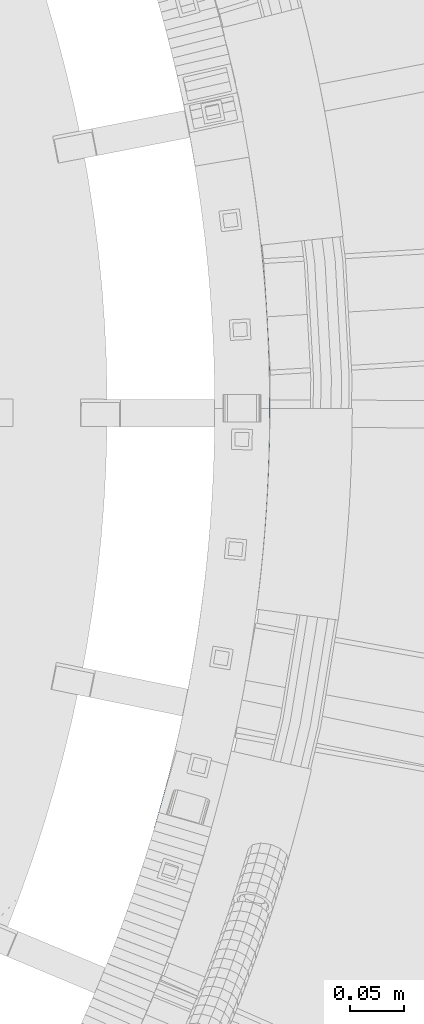
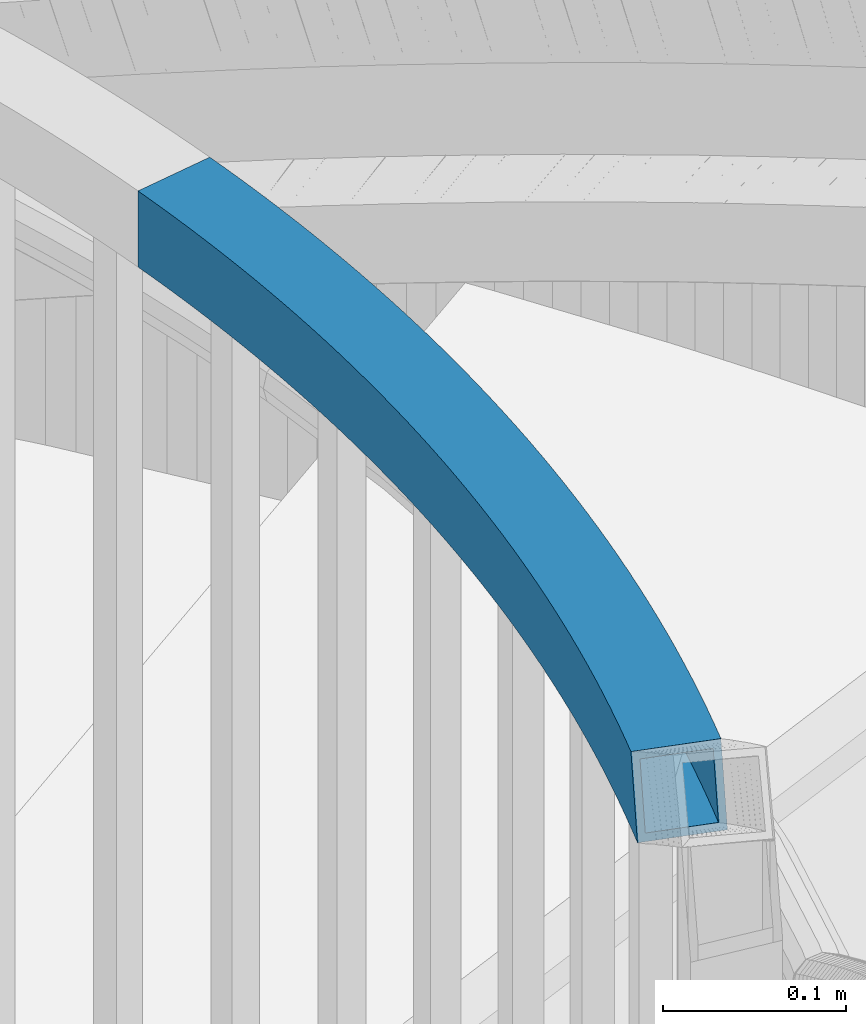
# One storey, part 499 of 975: 1 beam.
"""IFC2X3 building model written with IfcOpenShell, lengths in millimetres."""

import ifcopenshell
import ifcopenshell.guid

model = None  # the IFC model being written
_history = None  # IfcOwnerHistory: only IFC2X3 demands one
_inside = {}  # id of a spatial element -> (the spatial element, [elements in it])
_under = {}  # id of a project, library or spatial element -> (it, [spatial elements below it])
_declared = {}  # id of a project -> (the project, [libraries it declares])
_typed = {}  # id of a type object -> (the type object, [elements of that type])
_made_of = {}  # id of a material, layer set ... -> (it, [elements and type objects made of it])


def new_model(schema):
    """Start an empty IFC model of exactly this schema.

    Asked for "IFC4X3", IfcOpenShell would pick the latest addendum, in which some entities
    have other attributes; the version numbers below select the first issue.
    IFC2X3 requires an IfcOwnerHistory on every rooted entity: one is made here for all.
    """
    global model, _history
    if schema == "IFC4X3":
        model = ifcopenshell.file(schema_version=(4, 3, 0, 0))
    else:
        model = ifcopenshell.file(schema=schema)
    _inside.clear()
    _under.clear()
    _declared.clear()
    _typed.clear()
    _made_of.clear()
    _history = None
    if model.schema == "IFC2X3":
        org = make("IfcOrganization", Name="unknown")
        user = make(
            "IfcPersonAndOrganization",
            ThePerson=make("IfcPerson", FamilyName="unknown"),
            TheOrganization=org,
        )
        app = make(
            "IfcApplication",
            ApplicationDeveloper=org,
            Version="unknown",
            ApplicationFullName="unknown",
            ApplicationIdentifier="unknown",
        )
        _history = make(
            "IfcOwnerHistory",
            OwningUser=user,
            OwningApplication=app,
            ChangeAction="ADDED",
            CreationDate=0,
        )
    return model


def make(cls, **values):
    """One entity of the class cls with the attributes given. An attribute that is None is left unset."""
    return model.create_entity(
        cls, **{name: value for name, value in values.items() if value is not None}
    )


def rooted(cls, **values):
    """An entity with a GlobalId (a new one), such as an element, a storey or a relation."""
    return make(cls, GlobalId=ifcopenshell.guid.new(), OwnerHistory=_history, **values)


def si_unit(unit_type, name, prefix=None):
    """IfcSIUnit, for example si_unit("LENGTHUNIT", "METRE", prefix="MILLI")."""
    return make("IfcSIUnit", UnitType=unit_type, Prefix=prefix, Name=name)


def assignment(units):
    """IfcUnitAssignment: the units of a project."""
    return None if units is None else make("IfcUnitAssignment", Units=units)


def point(xyz):
    """IfcCartesianPoint."""
    return None if xyz is None else make("IfcCartesianPoint", Coordinates=xyz)


def direction(xyz):
    """IfcDirection."""
    return None if xyz is None else make("IfcDirection", DirectionRatios=xyz)


def frame(location, z_axis=None, x_axis=None):
    """IfcAxis2Placement3D, a coordinate frame: its origin and axes. An axis left out is left unset."""
    return make(
        "IfcAxis2Placement3D",
        Location=point(location),
        Axis=direction(z_axis),
        RefDirection=direction(x_axis),
    )


def origin_with_axes():
    """The frame at (0, 0, 0) with the z axis (0, 0, 1) and the x axis (1, 0, 0) written out."""
    return frame((0.0, 0.0, 0.0), z_axis=(0.0, 0.0, 1.0), x_axis=(1.0, 0.0, 0.0))


def place(relative_to, where):
    """IfcLocalPlacement: puts the frame where relative to a parent placement (None: the world)."""
    return make(
        "IfcLocalPlacement", PlacementRelTo=relative_to, RelativePlacement=where
    )


def context(
    kind, dimensions, precision=None, world=None, true_north=None, identifier=None
):
    """IfcGeometricRepresentationContext, for example the 3D "Model" context."""
    return make(
        "IfcGeometricRepresentationContext",
        ContextIdentifier=identifier,
        ContextType=kind,
        CoordinateSpaceDimension=dimensions,
        Precision=precision,
        WorldCoordinateSystem=world,
        TrueNorth=true_north,
    )


def subcontext(parent, identifier, kind, view, scale=None):
    """IfcGeometricRepresentationSubContext, for example "Body" below "Model"."""
    return make(
        "IfcGeometricRepresentationSubContext",
        ContextIdentifier=identifier,
        ContextType=kind,
        ParentContext=parent,
        TargetScale=scale,
        TargetView=view,
    )


def project(units=None, contexts=None):
    """IfcProject with its units and contexts."""
    return rooted(
        "IfcProject",
        Name="project",
        RepresentationContexts=contexts,
        UnitsInContext=assignment(units),
    )


def spatial(cls, under=None, at=None, **own):
    """A site, building, storey or space (cls), placed at a placement, below another one or the project."""
    s = rooted(cls, ObjectPlacement=at, **own)
    if under is not None:
        _under.setdefault(under.id(), (under, []))[1].append(s)
    return s


def faces_of(points, faces, orient=None, outer=None):
    """IfcFace entities. A face is a list of loops; a loop is a list of indices into points, from 0.

    orient and outer hold one flag for each loop. By default every Orientation is true, the
    first loop of a face is its IfcFaceOuterBound and the others are IfcFaceBound.
    """
    made = []
    for i, loops in enumerate(faces):
        bounds = []
        for j, loop in enumerate(loops):
            is_outer = j == 0 if outer is None else outer[i][j]
            bounds.append(
                make(
                    "IfcFaceOuterBound" if is_outer else "IfcFaceBound",
                    Bound=make("IfcPolyLoop", Polygon=[points[k] for k in loop]),
                    Orientation=True if orient is None else orient[i][j],
                )
            )
        made.append(make("IfcFace", Bounds=bounds))
    return made


def faceted_brep(points, faces, orient=None, outer=None, voids=None):
    """IfcFacetedBrep: a solid bounded by flat faces; with voids (closed shells), ...WithVoids."""
    shared = [point(p) for p in points]
    hull = make("IfcClosedShell", CfsFaces=faces_of(shared, faces, orient, outer))
    if voids is None:
        return make("IfcFacetedBrep", Outer=hull)
    return make(
        "IfcFacetedBrepWithVoids",
        Outer=hull,
        Voids=[
            make(cls, CfsFaces=faces_of(shared, fs, o, b)) for cls, fs, o, b in voids
        ],
    )


def shape(context_of_items, identifier, shape_type, items):
    """IfcShapeRepresentation: the items that make up one representation, for example the "Body"."""
    return make(
        "IfcShapeRepresentation",
        ContextOfItems=context_of_items,
        RepresentationIdentifier=identifier,
        RepresentationType=shape_type,
        Items=items,
    )


def material(Name=None, Category=None):
    """IfcMaterial."""
    return make("IfcMaterial", Name=Name, Category=Category)


def made_of(thing, what):
    """Note that an element or type object is made of a material, layer set ...; save() writes the relation."""
    if what is not None:
        _made_of.setdefault(what.id(), (what, []))[1].append(thing)
    return thing


def type_object(cls, material=None, **own):
    """A type object (cls), such as IfcWallType, which elements share."""
    return made_of(rooted(cls, **own), material)


def element(
    cls,
    number,
    at=None,
    inside=None,
    cuts=None,
    type_object=None,
    material=None,
    context=None,
    identifier="Body",
    shape_type=None,
    held_by="IfcProductDefinitionShape",
    body=None,
    shapes=None,
    **own,
):
    """One element of the class cls, such as IfcWall. Its Tag is "e" and its number.

    at: its placement. inside: the storey or other place that contains it. cuts: it is an
    opening in that element (IfcRelVoidsElement). A single representation is given by context,
    identifier, shape_type and body (its items); several are given by shapes. held_by: the class
    of the entity that holds the representations. save() writes the other relations.
    """
    e = rooted(cls, Tag="e%d" % number, ObjectPlacement=at, **own)
    if body is not None:
        shapes = [shape(context, identifier, shape_type, body)]
    if shapes is not None:
        e.Representation = make(held_by, Representations=shapes)
    if inside is not None:
        _inside.setdefault(inside.id(), (inside, []))[1].append(e)
    if cuts is not None:
        rooted(
            "IfcRelVoidsElement", RelatingBuildingElement=cuts, RelatedOpeningElement=e
        )
    if type_object is not None:
        _typed.setdefault(type_object.id(), (type_object, []))[1].append(e)
    return made_of(e, material)


def aggregate(whole, parts):
    """IfcRelAggregates: a whole, such as a stair, and the parts it consists of."""
    return rooted("IfcRelAggregates", RelatingObject=whole, RelatedObjects=parts)


def save(model, path):
    """Write the relations noted so far, then the file.

    IfcRelAggregates (storeys below a building ...), IfcRelContainedInSpatialStructure (elements
    in a storey), IfcRelDefinesByType, IfcRelAssociatesMaterial and IfcRelDeclares: one each for
    every whole, place, type object, material and project.
    """
    for whole, parts in _under.values():
        aggregate(whole, parts)
    for where, things in _inside.values():
        rooted(
            "IfcRelContainedInSpatialStructure",
            RelatedElements=things,
            RelatingStructure=where,
        )
    for kind, things in _typed.values():
        rooted("IfcRelDefinesByType", RelatedObjects=things, RelatingType=kind)
    for what, things in _made_of.values():
        rooted("IfcRelAssociatesMaterial", RelatedObjects=things, RelatingMaterial=what)
    for by, libraries in _declared.values():
        rooted("IfcRelDeclares", RelatingContext=by, RelatedDefinitions=libraries)
    model.write(path)


model = new_model("IFC2X3")

# Units and contexts
model_context = context("Model", 3, precision=1e-05, world=origin_with_axes())
body_context = subcontext(model_context, "Body", "Model", "MODEL_VIEW")
ifc_project = project(units=[si_unit("LENGTHUNIT", "METRE", prefix="MILLI"), si_unit("AREAUNIT", "SQUARE_METRE"), si_unit("VOLUMEUNIT", "CUBIC_METRE"), si_unit("MASSUNIT", "GRAM", prefix="KILO"), si_unit("TIMEUNIT", "SECOND"), si_unit("PLANEANGLEUNIT", "RADIAN"), si_unit("SOLIDANGLEUNIT", "STERADIAN"), si_unit("THERMODYNAMICTEMPERATUREUNIT", "DEGREE_CELSIUS"), si_unit("LUMINOUSINTENSITYUNIT", "LUMEN")], contexts=[model_context])

# Site, building, storey
site_placement = place(None, origin_with_axes())
site = spatial("IfcSite", under=ifc_project, at=site_placement, CompositionType="ELEMENT")
building_placement = place(site_placement, origin_with_axes())
building = spatial("IfcBuilding", under=site, at=building_placement, Name="Undefined", CompositionType="ELEMENT")
storey_placement = place(building_placement, origin_with_axes())
storey = spatial("IfcBuildingStorey", under=building, at=storey_placement, Name="Undefined", CompositionType="ELEMENT", Elevation=0.0)

# Beam
ifc_material = material()
beam_type = type_object("IfcBeamType", Name="HSS2X2X.188_TUBES", PredefinedType="NOTDEFINED")
beam_placement = place(storey_placement, frame((36112.9028262379, 3631.8040730418, 3175.0), z_axis=(0.0, 0.0, 1.0), x_axis=(-0.152973320974865, -0.988230318837629, 0.0)))
element("IfcBeam", 1, at=beam_placement, inside=storey, type_object=beam_type, material=ifc_material, Name="HANDRAIL", ObjectType="HSS2X2X.188_TUBES", context=body_context, shape_type="Brep", body=[
    faceted_brep([(576.212018865286, 37.0006519713424, 25.4000000000001), (576.212018865286, 37.0006519713424, -25.4000000000001), (590.890737316782, 35.4214520288515, -25.4000000000001), (590.890737316782, 35.4214520288515, 25.4000000000001), (561.517219100075, 38.4224493187139, 25.4000000000001), (561.517219100075, 38.4224493187139, -25.4000000000001), (546.808025829127, 39.686680766863, 25.4000000000001), (546.808025829127, 39.686680766863, -25.4000000000001), (532.08612851362, 40.7932011093435, 25.4000000000001), (532.08612851362, 40.7932011093435, -25.4000000000001), (517.353218073889, 41.741883253977, 25.4000000000001), (517.353218073889, 41.741883253977, -25.4000000000001), (502.610986695212, 42.5326182375138, 25.4000000000001), (502.610986695212, 42.5326182375138, -25.4000000000001), (487.861127633441, 43.1653152381041, 25.4000000000001), (487.861127633441, 43.1653152381041, -25.4000000000001), (473.105335020529, 43.6399015857533, 25.4000000000001), (473.105335020529, 43.6399015857533, -25.4000000000001), (458.345303669939, 43.9563227706531, 25.4000000000001), (458.345303669939, 43.9563227706531, -25.4000000000001), (443.582728881989, 44.114542449468, 25.4000000000001), (443.582728881989, 44.114542449468, -25.4000000000001), (428.819306249121, 44.1145424494753, 25.4000000000001), (428.819306249121, 44.1145424494753, -25.4000000000001), (414.056731461169, 43.9563227706749, 25.4000000000001), (414.056731461169, 43.9563227706749, -25.4000000000001), (399.296700110579, 43.6399015857896, 25.4000000000001), (399.296700110579, 43.6399015857896, -25.4000000000001), (384.540907497667, 43.165315238155, 25.4000000000001), (384.540907497667, 43.165315238155, -25.4000000000001), (369.791048435894, 42.5326182375866, 25.4000000000001), (369.791048435894, 42.5326182375866, -25.4000000000001), (355.048817057217, 41.7418832540643, 25.4000000000001), (355.048817057217, 41.7418832540643, -25.4000000000001), (340.315906617489, 40.7932011094526, 25.4000000000001), (340.315906617489, 40.7932011094526, -25.4000000000001), (325.59400930198, 39.6866807669794, 25.4000000000001), (325.59400930198, 39.6866807669794, -25.4000000000001), (310.88481603103, 38.4224493188449, 25.4000000000001), (310.88481603103, 38.4224493188449, -25.4000000000001), (296.190016265817, 37.000651971488, 25.4000000000001), (296.190016265817, 37.000651971488, -25.4000000000001), (281.511297814321, 35.4214520290116, 25.4000000000001), (281.511297814321, 35.4214520290116, -25.4000000000001), (266.850346637457, 33.6850308743669, 25.4000000000001), (266.850346637457, 33.6850308743669, -25.4000000000001), (252.208846655445, 31.7915879485518, 25.4000000000001), (252.208846655445, 31.7915879485518, -25.4000000000001), (237.588479554377, 29.7413407276836, 25.4000000000001), (237.588479554377, 29.7413407276836, -25.4000000000001), (222.990924593087, 27.5345246980505, 25.4000000000001), (222.990924593087, 27.5345246980505, -25.4000000000001), (208.417858410252, 25.1713933290084, 25.4000000000001), (208.417858410252, 25.1713933290084, -25.4000000000001), (193.87095483184, 22.6522180439206, 25.4000000000001), (193.87095483184, 22.6522180439206, -25.4000000000001), (179.351884678839, 19.9772881889803, 25.4000000000001), (179.351884678839, 19.9772881889803, -25.4000000000001), (164.862315575365, 17.146910999938, 25.4000000000001), (164.862315575365, 17.146910999938, -25.4000000000001), (150.403911757116, 14.1614115668417, 25.4000000000001), (150.403911757116, 14.1614115668417, -25.4000000000001), (135.978333880219, 11.0211327966972, 25.4000000000001), (135.978333880219, 11.0211327966972, -25.4000000000001), (121.587238830503, 7.72643537408294, 25.4000000000001), (121.587238830503, 7.72643537408294, -25.4000000000001), (107.23227953318, 4.27769771969906, 25.4000000000001), (107.23227953318, 4.27769771969906, -25.4000000000001), (92.9151047630003, 0.675315946937189, 25.4000000000001), (92.9151047630003, 0.675315946937189, -25.4000000000001), (78.6373589548784, -3.08029618362343, 25.4000000000001), (78.6373589548784, -3.08029618362343, -25.4000000000001), (64.4006820150189, -6.98870731177158, 25.4000000000001), (64.4006820150189, -6.98870731177158, -25.4000000000001), (50.2067091325571, -11.0494685271697, 25.4000000000001), (50.2067091325571, -11.0494685271697, -25.4000000000001), (36.0570705917453, -15.2621134209257, 25.4000000000001), (36.0570705917453, -15.2621134209257, -25.4000000000001), (21.953391584706, -19.6261581391882, 25.4000000000001), (21.953391584706, -19.6261581391882, -25.4000000000001), (7.89729202476701, -24.1411014386758, 25.4000000000001), (7.89729202476701, -24.1411014386758, -25.4000000000001), (611.79684408377, 84.0996917541634, -25.4000000000001), (611.79684408377, 84.0996917541634, 19.4647031772424), (624.828746712075, 82.4144024141278, -25.4000000000001), (605.551688493641, 33.685030874185, -25.4000000000001), (-7.89729202476883, 24.1411014386977, -25.4000000000001), (6.67715522320032, 28.8225425927812, -25.4000000000001), (21.3009365086018, 33.3475204689603, -25.4000000000001), (35.9723721804585, 37.7155153395652, -25.4000000000001), (50.6897771143394, 41.9260255076224, -25.4000000000001), (65.4514609058879, 45.9785673644583, -25.4000000000001), (80.2557280649962, 49.8726754452509, -25.4000000000001), (95.1008782105346, 53.6079024824721, -25.4000000000001), (109.985206265656, 57.1838194572701, -25.4000000000001), (124.907002653636, 60.6000156487644, -25.4000000000001), (139.864553494232, 63.8560986812081, -25.4000000000001), (154.856140800535, 66.9516945690193, -25.4000000000001), (169.88004267629, 69.8864477598108, -25.4000000000001), (184.934533513673, 72.6600211751575, -25.4000000000001), (200.017884191491, 75.2720962493404, -25.4000000000001), (215.128362273776, 77.7223729659527, -25.4000000000001), (230.264232208776, 80.0105698923362, -25.4000000000001), (245.4237555283, 82.1364242119089, -25.4000000000001), (260.60519104738, 84.099691754338, -25.4000000000001), (275.806795064273, 85.9001470236472, -25.4000000000001), (291.02682156073, 87.5375832240388, -25.4000000000001), (306.263522402543, 89.011812283672, -25.4000000000001), (321.515147540333, 90.3226648762793, -25.4000000000001), (336.77994521055, 91.4699904406152, -25.4000000000001), (352.056162136678, 92.4536571977296, -25.4000000000001), (367.342043730621, 93.2735521661307, -25.4000000000001), (382.635834294217, 93.929581174707, -25.4000000000001), (397.9357772209, 94.4216688736196, -25.4000000000001), (413.240115197463, 94.749758742917, -25.4000000000001), (428.547090405893, 94.9138130989886, -25.4000000000001), (443.854944725268, 94.9138130989813, -25.4000000000001), (459.161919933696, 94.7497587428879, -25.4000000000001), (474.466257910261, 94.4216688735833, -25.4000000000001), (489.766200836944, 93.9295811746488, -25.4000000000001), (505.059991400538, 93.2735521660506, -25.4000000000001), (520.34587299448, 92.4536571976423, -25.4000000000001), (535.622089920607, 91.4699904405134, -25.4000000000001), (550.886887590823, 90.3226648761556, -25.4000000000001), (566.13851272861, 89.0118122835338, -25.4000000000001), (581.375213570424, 87.5375832238788, -25.4000000000001), (596.595240066879, 85.9001470234871, -25.4000000000001), (618.617982637914, 31.9952940135699, -25.4000000000001), (605.551688493641, 33.685030874185, 19.5831022475577), (603.859815116853, 33.8854138293609, 25.4000000000001), (596.595240066879, 85.9001470234871, 25.4000000000001), (581.375213570424, 87.5375832238788, 25.4000000000001), (566.13851272861, 89.0118122835338, 25.4000000000001), (550.886887590823, 90.3226648761556, 25.4000000000001), (535.622089920607, 91.4699904405134, 25.4000000000001), (520.34587299448, 92.4536571976423, 25.4000000000001), (505.059991400538, 93.2735521660506, 25.4000000000001), (489.766200836944, 93.9295811746488, 25.4000000000001), (474.466257910261, 94.4216688735833, 25.4000000000001), (459.161919933696, 94.7497587428879, 25.4000000000001), (443.854944725268, 94.9138130989813, 25.4000000000001), (428.547090405893, 94.9138130989886, 25.4000000000001), (413.240115197463, 94.749758742917, 25.4000000000001), (397.9357772209, 94.4216688736196, 25.4000000000001), (382.635834294217, 93.929581174707, 25.4000000000001), (367.342043730621, 93.2735521661307, 25.4000000000001), (352.056162136678, 92.4536571977296, 25.4000000000001), (336.77994521055, 91.4699904406152, 25.4000000000001), (321.515147540333, 90.3226648762793, 25.4000000000001), (306.263522402543, 89.011812283672, 25.4000000000001), (291.02682156073, 87.5375832240388, 25.4000000000001), (275.806795064273, 85.9001470236472, 25.4000000000001), (260.60519104738, 84.099691754338, 25.4000000000001), (245.4237555283, 82.1364242119089, 25.4000000000001), (230.264232208776, 80.0105698923362, 25.4000000000001), (215.128362273776, 77.7223729659527, 25.4000000000001), (200.017884191491, 75.2720962493404, 25.4000000000001), (184.934533513673, 72.6600211751575, 25.4000000000001), (169.88004267629, 69.8864477598108, 25.4000000000001), (154.856140800535, 66.9516945690193, 25.4000000000001), (139.864553494232, 63.8560986812081, 25.4000000000001), (124.907002653636, 60.6000156487644, 25.4000000000001), (109.985206265656, 57.1838194572701, 25.4000000000001), (95.1008782105346, 53.6079024824721, 25.4000000000001), (80.2557280649962, 49.8726754452509, 25.4000000000001), (65.4514609058879, 45.9785673644583, 25.4000000000001), (50.6897771143394, 41.9260255076224, 25.4000000000001), (35.9723721804585, 37.7155153395652, 25.4000000000001), (21.3009365086018, 33.3475204689603, 25.4000000000001), (6.67715522320032, 28.8225425927812, 25.4000000000001), (-7.89729202476883, 24.1411014386977, 25.4000000000001), (610.070533753915, 84.3041533706128, 25.4000000000001), (576.696068368892, 41.7384892762639, -20.6374999999998), (576.696068368892, 41.7384892762639, 20.6374999999998), (591.425534449601, 40.1538296845974, 20.6374999999998), (591.425534449601, 40.1538296845974, -20.6374999999998), (561.950465377751, 43.1652020966649, -20.6374999999998), (561.950465377751, 43.1652020966649, 20.6374999999998), (547.190419119284, 44.4338042771196, -20.6374999999998), (547.190419119284, 44.4338042771196, 20.6374999999998), (532.417624895525, 45.5441501091409, -20.6374999999998), (532.417624895525, 45.5441501091409, 20.6374999999998), (517.633779472695, 46.4961120612061, -20.6374999999998), (517.633779472695, 46.4961120612061, 20.6374999999998), (502.840580886337, 47.2895807933164, -20.6374999999998), (502.840580886337, 47.2895807933164, 20.6374999999998), (488.039728246271, 47.9244651696572, -20.6374999999998), (488.039728246271, 47.9244651696572, 20.6374999999998), (473.232921541443, 48.4006922689805, -20.6374999999998), (473.232921541443, 48.4006922689805, 20.6374999999998), (458.421861444667, 48.7182073930526, -20.6374999999998), (458.421861444667, 48.7182073930526, 20.6374999999998), (443.608249117297, 48.8769740728603, -20.6374999999998), (443.608249117297, 48.8769740728603, 20.6374999999998), (428.793786013819, 48.8769740728676, -20.6374999999998), (428.793786013819, 48.8769740728676, 20.6374999999998), (413.980173686447, 48.7182073930744, -20.6374999999998), (413.980173686447, 48.7182073930744, 20.6374999999998), (399.169113589673, 48.4006922690241, -20.6374999999998), (399.169113589673, 48.4006922690241, 20.6374999999998), (384.362306884843, 47.9244651697154, -20.6374999999998), (384.362306884843, 47.9244651697154, 20.6374999999998), (369.561454244777, 47.2895807933819, -20.6374999999998), (369.561454244777, 47.2895807933819, 20.6374999999998), (354.768255658417, 46.4961120612861, -20.6374999999998), (354.768255658417, 46.4961120612861, 20.6374999999998), (339.984410235587, 45.5441501092428, -20.6374999999998), (339.984410235587, 45.5441501092428, 20.6374999999998), (325.211616011826, 44.4338042772288, -20.6374999999998), (325.211616011826, 44.4338042772288, 20.6374999999998), (310.451569753359, 43.1652020967958, -20.6374999999998), (310.451569753359, 43.1652020967958, 20.6374999999998), (295.705966762214, 41.7384892764167, -20.6374999999998), (295.705966762214, 41.7384892764167, 20.6374999999998), (280.976500681503, 40.1538296847575, -20.6374999999998), (280.976500681503, 40.1538296847575, 20.6374999999998), (266.264863300888, 38.4114053318626, -20.6374999999998), (266.264863300888, 38.4114053318626, 20.6374999999998), (251.572744362275, 36.5114163482431, -20.6374999999998), (251.572744362275, 36.5114163482431, 20.6374999999998), (236.901831365729, 34.4540809618702, -20.6374999999998), (236.901831365729, 34.4540809618702, 20.6374999999998), (222.25380937565, 32.2396354731609, -20.6374999999998), (222.25380937565, 32.2396354731609, 20.6374999999998), (207.630360827243, 29.8683342277873, -20.6374999999998), (207.630360827243, 29.8683342277873, 20.6374999999998), (193.03316533326, 27.3404495874856, -20.6374999999998), (193.03316533326, 27.3404495874856, 20.6374999999998), (178.4638994911, 24.6562718987479, -20.6374999999998), (178.4638994911, 24.6562718987479, 20.6374999999998), (163.924236690224, 21.8161094595416, -20.6374999999998), (163.924236690224, 21.8161094595416, 20.6374999999998), (149.415846919968, 18.8202884838174, -20.6374999999998), (149.415846919968, 18.8202884838174, 20.6374999999998), (134.940396577727, 15.6691530640819, -20.6374999999998), (134.940396577727, 15.6691530640819, 20.6374999999998), (120.499548277548, 12.3630651318817, -20.6374999999998), (120.499548277548, 12.3630651318817, 20.6374999999998), (106.094960659182, 8.90240441619972, -20.6374999999998), (106.094960659182, 8.90240441619972, 20.6374999999998), (91.7282881975625, 5.28756839990092, -20.6374999999998), (91.7282881975625, 5.28756839990092, 20.6374999999998), (77.4011810127849, 1.51897227401059, -20.6374999999998), (77.4011810127849, 1.51897227401059, 20.6374999999998), (63.1152846805817, -2.40295110995794, -20.6374999999998), (63.1152846805817, -2.40295110995794, 20.6374999999998), (48.872240043298, -6.47775128966896, -20.6374999999998), (48.872240043298, -6.47775128966896, 20.6374999999998), (34.6736830214504, -10.7049602437473, -20.6374999999998), (34.6736830214504, -10.7049602437473, 20.6374999999998), (20.5212444258141, -15.0840924455624, -20.6374999999998), (20.5212444258141, -15.0840924455624, 20.6374999999998), (6.41654977012149, -19.6146449189182, -20.6374999999998), (6.41654977012149, -19.6146449189182, 20.6374999999998), (-6.41654977012513, 19.6146449189328, 20.6374999999998), (-6.41654977012513, 19.6146449189328, -20.6374999999998), (8.10930238209221, 24.2804768991555, -20.6374999999998), (8.10930238209221, 24.2804768991555, 20.6374999999998), (22.6843240788967, 28.7903672917819, -20.6374999999998), (22.6843240788967, 28.7903672917819, 20.6374999999998), (37.3068412697176, 33.1437981020645, -20.6374999999998), (37.3068412697176, 33.1437981020645, 20.6374999999998), (51.9751744487785, 37.3402693058088, -20.6374999999998), (51.9751744487785, 37.3402693058088, 20.6374999999998), (66.6876388479795, 41.3792989068315, -20.6374999999998), (66.6876388479795, 41.3792989068315, 20.6374999999998), (81.442544630434, 45.2604229922872, -20.6374999999998), (81.442544630434, 45.2604229922872, 20.6374999999998), (96.2381970845327, 48.9831957859569, -20.6374999999998), (96.2381970845327, 48.9831957859569, 20.6374999999998), (111.07289681861, 52.5471896994713, -20.6374999999998), (111.07289681861, 52.5471896994713, 20.6374999999998), (125.944939956127, 55.9519953813942, -20.6374999999998), (125.944939956127, 55.9519953813942, 20.6374999999998), (140.852618331377, 59.1972217642397, -20.6374999999998), (140.852618331377, 59.1972217642397, 20.6374999999998), (155.794219685675, 62.2824961094157, -20.6374999999998), (155.794219685675, 62.2824961094157, 20.6374999999998), (170.768027864029, 65.2074640500432, -20.6374999999998), (170.768027864029, 65.2074640500432, 20.6374999999998), (185.772323012252, 67.971789631607, -20.6374999999998), (185.772323012252, 67.971789631607, 20.6374999999998), (200.805381774499, 70.5751553505615, -20.6374999999998), (200.805381774499, 70.5751553505615, 20.6374999999998), (215.86547749121, 73.0172621908423, -20.6374999999998), (215.86547749121, 73.0172621908423, 20.6374999999998), (230.950880397428, 75.2978296581496, -20.6374999999998), (230.950880397428, 75.2978296581496, 20.6374999999998), (246.05985782147, 77.4165958122103, -20.6374999999998), (246.05985782147, 77.4165958122103, 20.6374999999998), (261.19067438395, 79.3733172968496, -20.6374999999998), (261.19067438395, 79.3733172968496, 20.6374999999998), (276.34159219709, 81.1677693679012, -20.6374999999998), (276.34159219709, 81.1677693679012, 20.6374999999998), (291.510871064333, 82.7997459191101, -20.6374999999998), (291.510871064333, 82.7997459191101, 20.6374999999998), (306.696768680215, 84.2690595057211, -20.6374999999998), (306.696768680215, 84.2690595057211, 20.6374999999998), (321.897540830489, 85.5755413660299, -20.6374999999998), (321.897540830489, 85.5755413660299, 20.6374999999998), (337.111441592449, 86.7190414408251, -20.6374999999998), (337.111441592449, 86.7190414408251, 20.6374999999998), (352.33672353548, 87.6994283905224, -20.6374999999998), (352.33672353548, 87.6994283905224, 20.6374999999998), (367.571637921741, 88.5165896103281, -20.6374999999998), (367.571637921741, 88.5165896103281, 20.6374999999998), (382.814434907039, 89.1704312431539, -20.6374999999998), (382.814434907039, 89.1704312431539, 20.6374999999998), (398.063363741807, 89.6608781903851, -20.6374999999998), (398.063363741807, 89.6608781903851, 20.6374999999998), (413.316672972185, 89.9878741205175, -20.6374999999998), (413.316672972185, 89.9878741205175, 20.6374999999998), (428.572610641197, 90.1513814755963, -20.6374999999998), (428.572610641197, 90.1513814755963, 20.6374999999998), (443.829424489961, 90.151381475589, -20.6374999999998), (443.829424489961, 90.151381475589, 20.6374999999998), (459.08536215897, 89.9878741204884, -20.6374999999998), (459.08536215897, 89.9878741204884, 20.6374999999998), (474.338671389349, 89.6608781903487, -20.6374999999998), (474.338671389349, 89.6608781903487, 20.6374999999998), (489.587600224117, 89.1704312431029, -20.6374999999998), (489.587600224117, 89.1704312431029, 20.6374999999998), (504.830397209415, 88.5165896102626, -20.6374999999998), (504.830397209415, 88.5165896102626, 20.6374999999998), (520.065311595674, 87.6994283904205, -20.6374999999998), (520.065311595674, 87.6994283904205, 20.6374999999998), (535.290593538703, 86.719041440716, -20.6374999999998), (535.290593538703, 86.719041440716, 20.6374999999998), (550.504494300663, 85.5755413659208, -20.6374999999998), (550.504494300663, 85.5755413659208, 20.6374999999998), (565.705266450936, 84.2690595055756, -20.6374999999998), (565.705266450936, 84.2690595055756, 20.6374999999998), (580.891164066816, 82.7997459189573, -20.6374999999998), (580.891164066816, 82.7997459189573, 20.6374999999998), (596.060442934056, 81.1677693677411, -20.6374999999998), (596.060442934056, 81.1677693677411, 20.6374999999998), (611.211360747197, 79.3733172966604, -20.6374999999998), (622.86311865373, 77.8665086630717, -20.6374999999998), (611.211360747197, 79.3733172966604, 19.4758030900853), (610.873475476141, 79.4133359233892, 20.6374999999998), (605.827266583528, 38.4481100461198, 20.6374999999998), (606.137171830216, 38.411405331688, -20.6374999999998), (606.137171830216, 38.411405331688, 19.5720023347162), (617.816872843472, 36.9009830876166, -20.6374999999998)], [[[0, 1, 2, 3]], [[4, 5, 1, 0]], [[6, 7, 5, 4]], [[8, 9, 7, 6]], [[10, 11, 9, 8]], [[12, 13, 11, 10]], [[14, 15, 13, 12]], [[16, 17, 15, 14]], [[18, 19, 17, 16]], [[20, 21, 19, 18]], [[22, 23, 21, 20]], [[24, 25, 23, 22]], [[26, 27, 25, 24]], [[28, 29, 27, 26]], [[30, 31, 29, 28]], [[32, 33, 31, 30]], [[34, 35, 33, 32]], [[36, 37, 35, 34]], [[38, 39, 37, 36]], [[40, 41, 39, 38]], [[42, 43, 41, 40]], [[44, 45, 43, 42]], [[46, 47, 45, 44]], [[48, 49, 47, 46]], [[50, 51, 49, 48]], [[52, 53, 51, 50]], [[54, 55, 53, 52]], [[56, 57, 55, 54]], [[58, 59, 57, 56]], [[60, 61, 59, 58]], [[62, 63, 61, 60]], [[64, 65, 63, 62]], [[66, 67, 65, 64]], [[68, 69, 67, 66]], [[70, 71, 69, 68]], [[72, 73, 71, 70]], [[74, 75, 73, 72]], [[76, 77, 75, 74]], [[78, 79, 77, 76]], [[80, 81, 79, 78]], [[82, 83, 84]], [[85, 2, 1, 5, 7, 9, 11, 13, 15, 17, 19, 21, 23, 25, 27, 29, 31, 33, 35, 37, 39, 41, 43, 45, 47, 49, 51, 53, 55, 57, 59, 61, 63, 65, 67, 69, 71, 73, 75, 77, 79, 81, 86, 87, 88, 89, 90, 91, 92, 93, 94, 95, 96, 97, 98, 99, 100, 101, 102, 103, 104, 105, 106, 107, 108, 109, 110, 111, 112, 113, 114, 115, 116, 117, 118, 119, 120, 121, 122, 123, 124, 125, 126, 82, 84, 127]], [[85, 127, 128]], [[3, 2, 85, 128, 129]], [[130, 131, 132, 133, 134, 135, 136, 137, 138, 139, 140, 141, 142, 143, 144, 145, 146, 147, 148, 149, 150, 151, 152, 153, 154, 155, 156, 157, 158, 159, 160, 161, 162, 163, 164, 165, 166, 167, 168, 169, 170, 80, 78, 76, 74, 72, 70, 68, 66, 64, 62, 60, 58, 56, 54, 52, 50, 48, 46, 44, 42, 40, 38, 36, 34, 32, 30, 28, 26, 24, 22, 20, 18, 16, 14, 12, 10, 8, 6, 4, 0, 3, 129, 171]], [[82, 126, 130, 171, 83]], [[125, 131, 130, 126]], [[124, 132, 131, 125]], [[123, 133, 132, 124]], [[122, 134, 133, 123]], [[121, 135, 134, 122]], [[120, 136, 135, 121]], [[119, 137, 136, 120]], [[118, 138, 137, 119]], [[117, 139, 138, 118]], [[116, 140, 139, 117]], [[115, 141, 140, 116]], [[114, 142, 141, 115]], [[113, 143, 142, 114]], [[112, 144, 143, 113]], [[111, 145, 144, 112]], [[110, 146, 145, 111]], [[109, 147, 146, 110]], [[108, 148, 147, 109]], [[107, 149, 148, 108]], [[106, 150, 149, 107]], [[105, 151, 150, 106]], [[104, 152, 151, 105]], [[103, 153, 152, 104]], [[102, 154, 153, 103]], [[101, 155, 154, 102]], [[100, 156, 155, 101]], [[99, 157, 156, 100]], [[98, 158, 157, 99]], [[97, 159, 158, 98]], [[96, 160, 159, 97]], [[95, 161, 160, 96]], [[94, 162, 161, 95]], [[93, 163, 162, 94]], [[92, 164, 163, 93]], [[91, 165, 164, 92]], [[90, 166, 165, 91]], [[89, 167, 166, 90]], [[88, 168, 167, 89]], [[87, 169, 168, 88]], [[86, 170, 169, 87]], [[172, 173, 174, 175]], [[176, 177, 173, 172]], [[178, 179, 177, 176]], [[180, 181, 179, 178]], [[182, 183, 181, 180]], [[184, 185, 183, 182]], [[186, 187, 185, 184]], [[188, 189, 187, 186]], [[190, 191, 189, 188]], [[192, 193, 191, 190]], [[194, 195, 193, 192]], [[196, 197, 195, 194]], [[198, 199, 197, 196]], [[200, 201, 199, 198]], [[202, 203, 201, 200]], [[204, 205, 203, 202]], [[206, 207, 205, 204]], [[208, 209, 207, 206]], [[210, 211, 209, 208]], [[212, 213, 211, 210]], [[214, 215, 213, 212]], [[216, 217, 215, 214]], [[218, 219, 217, 216]], [[220, 221, 219, 218]], [[222, 223, 221, 220]], [[224, 225, 223, 222]], [[226, 227, 225, 224]], [[228, 229, 227, 226]], [[230, 231, 229, 228]], [[232, 233, 231, 230]], [[234, 235, 233, 232]], [[236, 237, 235, 234]], [[238, 239, 237, 236]], [[240, 241, 239, 238]], [[242, 243, 241, 240]], [[244, 245, 243, 242]], [[246, 247, 245, 244]], [[248, 249, 247, 246]], [[250, 251, 249, 248]], [[252, 253, 251, 250]], [[81, 80, 170, 86], [254, 253, 252, 255]], [[254, 255, 256, 257]], [[257, 256, 258, 259]], [[259, 258, 260, 261]], [[261, 260, 262, 263]], [[263, 262, 264, 265]], [[265, 264, 266, 267]], [[267, 266, 268, 269]], [[269, 268, 270, 271]], [[271, 270, 272, 273]], [[273, 272, 274, 275]], [[275, 274, 276, 277]], [[277, 276, 278, 279]], [[279, 278, 280, 281]], [[281, 280, 282, 283]], [[283, 282, 284, 285]], [[285, 284, 286, 287]], [[287, 286, 288, 289]], [[289, 288, 290, 291]], [[291, 290, 292, 293]], [[293, 292, 294, 295]], [[295, 294, 296, 297]], [[297, 296, 298, 299]], [[299, 298, 300, 301]], [[301, 300, 302, 303]], [[303, 302, 304, 305]], [[305, 304, 306, 307]], [[307, 306, 308, 309]], [[309, 308, 310, 311]], [[311, 310, 312, 313]], [[313, 312, 314, 315]], [[315, 314, 316, 317]], [[317, 316, 318, 319]], [[319, 318, 320, 321]], [[321, 320, 322, 323]], [[323, 322, 324, 325]], [[325, 324, 326, 327]], [[327, 326, 328, 329]], [[329, 328, 330, 331]], [[331, 330, 332, 333]], [[333, 332, 334, 335]], [[336, 337, 338]], [[335, 334, 336, 338, 339]], [[174, 173, 177, 179, 181, 183, 185, 187, 189, 191, 193, 195, 197, 199, 201, 203, 205, 207, 209, 211, 213, 215, 217, 219, 221, 223, 225, 227, 229, 231, 233, 235, 237, 239, 241, 243, 245, 247, 249, 251, 253, 254, 257, 259, 261, 263, 265, 267, 269, 271, 273, 275, 277, 279, 281, 283, 285, 287, 289, 291, 293, 295, 297, 299, 301, 303, 305, 307, 309, 311, 313, 315, 317, 319, 321, 323, 325, 327, 329, 331, 333, 335, 339, 340]], [[341, 175, 174, 340, 342]], [[341, 342, 343]], [[336, 334, 332, 330, 328, 326, 324, 322, 320, 318, 316, 314, 312, 310, 308, 306, 304, 302, 300, 298, 296, 294, 292, 290, 288, 286, 284, 282, 280, 278, 276, 274, 272, 270, 268, 266, 264, 262, 260, 258, 256, 255, 252, 250, 248, 246, 244, 242, 240, 238, 236, 234, 232, 230, 228, 226, 224, 222, 220, 218, 216, 214, 212, 210, 208, 206, 204, 202, 200, 198, 196, 194, 192, 190, 188, 186, 184, 182, 180, 178, 176, 172, 175, 341, 343, 337]], [[171, 129, 128, 127, 84, 83], [342, 340, 339, 338, 337, 343]]]),
])

save(model, "model.ifc")
